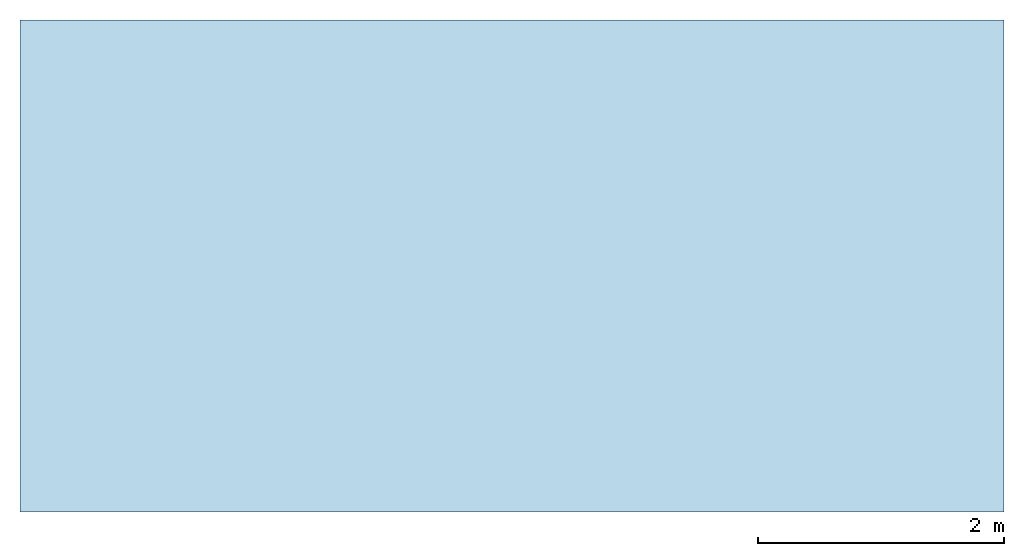
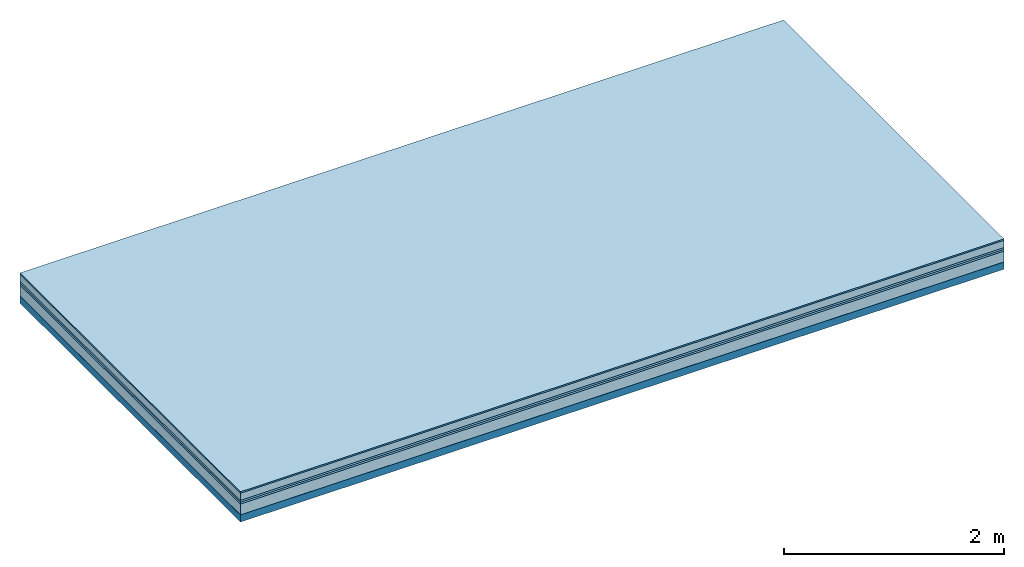
# One storey: 6 plates, 1 member, 1 element without a shape of its own.
"""IFC4 building model written with IfcOpenShell, lengths in metres."""

from ifc_helpers import new_model, si_unit, derived_unit, direction, frame, frame_2d, origin, origin_with_axes, place, context, project, spatial, rectangle, extrude, material, layer, layer_set, type_object, element, aggregate, save


model = new_model("IFC4")

# Units and contexts
plan_context = context("Plan", 3, precision=1e-05, world=origin(), true_north=direction((0.0, 1.0)))
model_context = context("Model", 3, precision=1e-05, world=origin(), true_north=direction((0.0, 1.0)))
ifc_project = project(units=[si_unit("LENGTHUNIT", "METRE"), derived_unit("SOUNDPRESSUREUNIT", [(si_unit("PRESSUREUNIT", "PASCAL", prefix="MICRO"), 0)]), si_unit("ENERGYUNIT", "JOULE", prefix="MEGA"), si_unit("MASSUNIT", "GRAM", prefix="KILO"), derived_unit("THERMALTRANSMITTANCEUNIT", [(si_unit("POWERUNIT", "WATT"), 1), (si_unit("AREAUNIT", "SQUARE_METRE"), -1), (si_unit("THERMODYNAMICTEMPERATUREUNIT", "KELVIN"), -1)]), derived_unit("AREADENSITYUNIT", [(si_unit("MASSUNIT", "GRAM", prefix="KILO"), 1), (si_unit("AREAUNIT", "SQUARE_METRE"), -1)]), derived_unit("USERDEFINED", [(si_unit("ENERGYUNIT", "JOULE", prefix="MEGA"), 1), (si_unit("AREAUNIT", "SQUARE_METRE"), -1)])], contexts=[plan_context, model_context])

# Site, building, storey
site = spatial("IfcSite", under=ifc_project)
building_placement = place(None, origin())
building = spatial("IfcBuilding", under=site, at=building_placement)
storey_placement = place(building_placement, origin())
storey = spatial("IfcBuildingStorey", under=building, at=storey_placement)

# Slab, member, plates
ifc_material_1 = material(Category="11.013")
ifc_layer_1 = layer(ifc_material_1, 0.015, Name="Flooring")
ifc_material_2 = material(Name="Cement screed", Category="04.006")
ifc_layer_2 = layer(ifc_material_2, 0.08, Name="On-material")
ifc_material_3 = material(Name="Wood fiber generic product", Category="10.009")
ifc_layer_3 = layer(ifc_material_3, 0.02, Name="Impact sound insulation")
ifc_material_4 = material()
ifc_layer_4 = layer(ifc_material_4, 0.02, Name="Additional insulation")
ifc_material_5 = material(Category="03.011")
ifc_layer_5 = layer(ifc_material_5, 0.12, Name="on Supporting structure")
ifc_material_6 = material(Name="protection", Category="09.007")
ifc_layer_6 = layer(ifc_material_6, 0.0005, Name="Sub-floor")
ifc_material_7 = material(Name="no composite action")
ifc_layer_7 = layer(ifc_material_7, 0.0, Name="Bond")
ifc_layer_8 = layer(None, 0.08, Name="Supporting structure")
ifc_layer_set = layer_set([ifc_layer_1, ifc_layer_2, ifc_layer_3, ifc_layer_4, ifc_layer_5, ifc_layer_6, ifc_layer_7, ifc_layer_8])
slab_type = type_object("IfcSlabType", Name="A2076", PredefinedType="NOTDEFINED", material=ifc_layer_set)
slab_placement = place(None, frame((0.0, 0.0, 0.0), z_axis=(0.0, 0.0, -1.0), x_axis=(1.0, 0.0, 0.0)))
slab = element("IfcSlab", 1, at=slab_placement, inside=storey, type_object=slab_type, material=ifc_layer_set, Name="Slab #1")
ifc_material_8 = material(Name="Solid timber panel")
member_placement = place(slab_placement, origin())
member = element("IfcMember", 2, at=member_placement, material=ifc_material_8, Name="Supporting structure", context=plan_context, shape_type="SweptSolid", body=[
    extrude(rectangle(XDim=1.0, YDim=0.08, at=frame_2d((0.5, 0.04), x_axis=(1.0, 0.0))), frame((0.0, 4.0, 0.2555), z_axis=(0.0, -1.0, 0.0), x_axis=(1.0, 0.0, 0.0)), (0.0, 0.0, 1.0), 4.0),
    extrude(rectangle(XDim=1.0, YDim=0.08, at=frame_2d((0.5, 0.04), x_axis=(1.0, 0.0))), frame((1.0, 4.0, 0.2555), z_axis=(0.0, -1.0, 0.0), x_axis=(1.0, 0.0, 0.0)), (0.0, 0.0, 1.0), 4.0),
    extrude(rectangle(XDim=1.0, YDim=0.08, at=frame_2d((0.5, 0.04), x_axis=(1.0, 0.0))), frame((2.0, 4.0, 0.2555), z_axis=(0.0, -1.0, 0.0), x_axis=(1.0, 0.0, 0.0)), (0.0, 0.0, 1.0), 4.0),
    extrude(rectangle(XDim=1.0, YDim=0.08, at=frame_2d((0.5, 0.04), x_axis=(1.0, 0.0))), frame((3.0, 4.0, 0.2555), z_axis=(0.0, -1.0, 0.0), x_axis=(1.0, 0.0, 0.0)), (0.0, 0.0, 1.0), 4.0),
    extrude(rectangle(XDim=1.0, YDim=0.08, at=frame_2d((0.5, 0.04), x_axis=(1.0, 0.0))), frame((4.0, 4.0, 0.2555), z_axis=(0.0, -1.0, 0.0), x_axis=(1.0, 0.0, 0.0)), (0.0, 0.0, 1.0), 4.0),
    extrude(rectangle(XDim=1.0, YDim=0.08, at=frame_2d((0.5, 0.04), x_axis=(1.0, 0.0))), frame((5.0, 4.0, 0.2555), z_axis=(0.0, -1.0, 0.0), x_axis=(1.0, 0.0, 0.0)), (0.0, 0.0, 1.0), 4.0),
    extrude(rectangle(XDim=1.0, YDim=0.08, at=frame_2d((0.5, 0.04), x_axis=(1.0, 0.0))), frame((6.0, 4.0, 0.2555), z_axis=(0.0, -1.0, 0.0), x_axis=(1.0, 0.0, 0.0)), (0.0, 0.0, 1.0), 4.0),
    extrude(rectangle(XDim=1.0, YDim=0.08, at=frame_2d((0.5, 0.04), x_axis=(1.0, 0.0))), frame((7.0, 4.0, 0.2555), z_axis=(0.0, -1.0, 0.0), x_axis=(1.0, 0.0, 0.0)), (0.0, 0.0, 1.0), 4.0),
])
plate_1_placement = place(slab_placement, origin())
plate_1 = element("IfcPlate", 3, at=plate_1_placement, material=ifc_material_1, Name="Flooring", context=plan_context, shape_type="SweptSolid", body=[
    extrude(rectangle(XDim=8.0, YDim=4.0, at=frame_2d((4.0, 2.0), x_axis=(1.0, 0.0))), origin_with_axes(), (0.0, 0.0, 1.0), 0.015),
])
plate_2_placement = place(slab_placement, origin())
plate_2 = element("IfcPlate", 4, at=plate_2_placement, material=ifc_material_2, Name="On-material", context=plan_context, shape_type="SweptSolid", body=[
    extrude(rectangle(XDim=8.0, YDim=4.0, at=frame_2d((4.0, 2.0), x_axis=(1.0, 0.0))), frame((0.0, 0.0, 0.015), z_axis=(0.0, 0.0, 1.0), x_axis=(1.0, 0.0, 0.0)), (0.0, 0.0, 1.0), 0.08),
])
plate_3_placement = place(slab_placement, origin())
plate_3 = element("IfcPlate", 5, at=plate_3_placement, material=ifc_material_3, Name="Impact sound insulation", context=plan_context, shape_type="SweptSolid", body=[
    extrude(rectangle(XDim=8.0, YDim=4.0, at=frame_2d((4.0, 2.0), x_axis=(1.0, 0.0))), frame((0.0, 0.0, 0.095), z_axis=(0.0, 0.0, 1.0), x_axis=(1.0, 0.0, 0.0)), (0.0, 0.0, 1.0), 0.02),
])
plate_4_placement = place(slab_placement, origin())
plate_4 = element("IfcPlate", 6, at=plate_4_placement, material=ifc_material_4, Name="Additional insulation", context=plan_context, shape_type="SweptSolid", body=[
    extrude(rectangle(XDim=8.0, YDim=4.0, at=frame_2d((4.0, 2.0), x_axis=(1.0, 0.0))), frame((0.0, 0.0, 0.115), z_axis=(0.0, 0.0, 1.0), x_axis=(1.0, 0.0, 0.0)), (0.0, 0.0, 1.0), 0.02),
])
plate_5_placement = place(slab_placement, origin())
plate_5 = element("IfcPlate", 7, at=plate_5_placement, material=ifc_material_5, Name="on Supporting structure", context=plan_context, shape_type="SweptSolid", body=[
    extrude(rectangle(XDim=8.0, YDim=4.0, at=frame_2d((4.0, 2.0), x_axis=(1.0, 0.0))), frame((0.0, 0.0, 0.135), z_axis=(0.0, 0.0, 1.0), x_axis=(1.0, 0.0, 0.0)), (0.0, 0.0, 1.0), 0.12),
])
plate_6_placement = place(slab_placement, origin())
plate_6 = element("IfcPlate", 8, at=plate_6_placement, material=ifc_material_6, Name="Sub-floor", context=plan_context, shape_type="SweptSolid", body=[
    extrude(rectangle(XDim=8.0, YDim=4.0, at=frame_2d((4.0, 2.0), x_axis=(1.0, 0.0))), frame((0.0, 0.0, 0.255), z_axis=(0.0, 0.0, 1.0), x_axis=(1.0, 0.0, 0.0)), (0.0, 0.0, 1.0), 0.0005),
])
aggregate(slab, [plate_1, plate_2, plate_3, plate_4, plate_5, plate_6, member])

save(model, "model.ifc")
